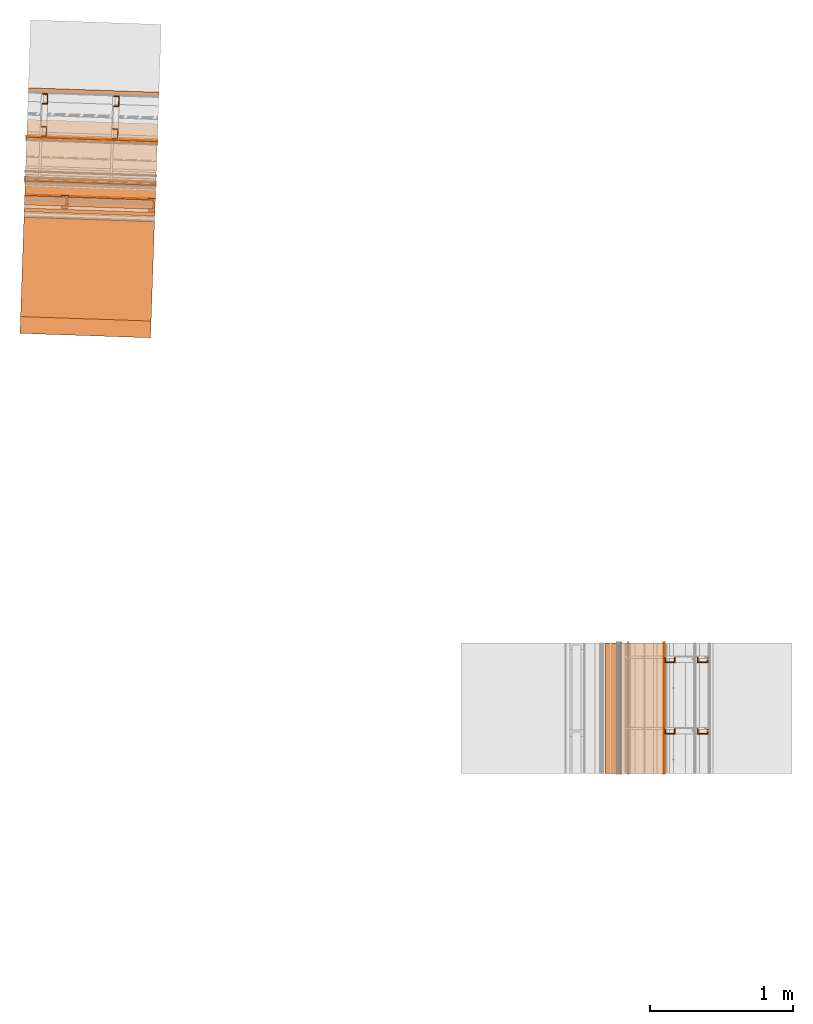
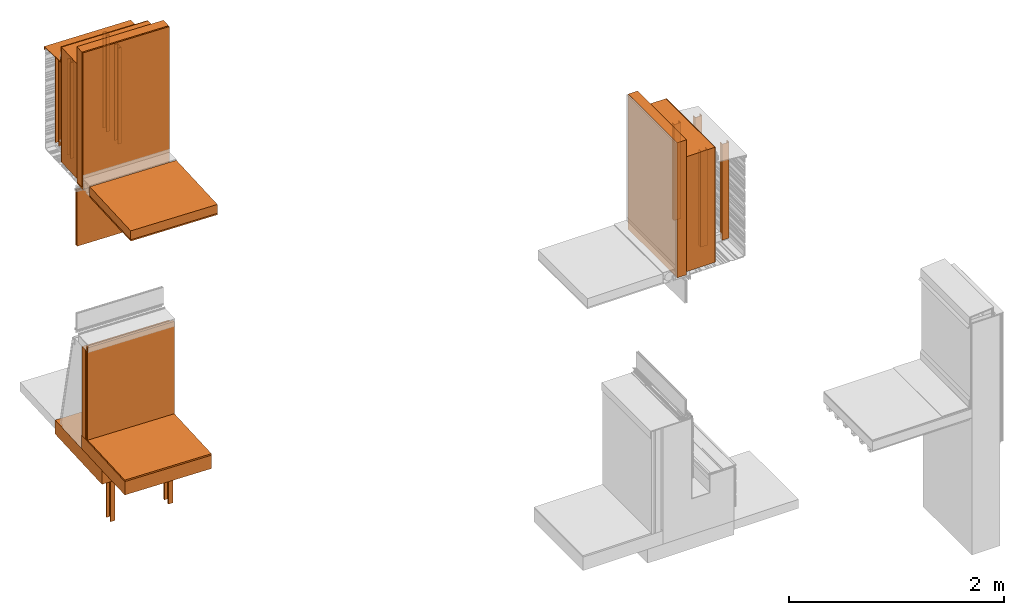
# One storey, part 2 of 36: 27 proxies.
"""IFC2X3 building model written with IfcOpenShell, lengths in feet."""

from ifc_helpers import new_model, entity, si_unit, converted_unit, derived_unit, direction, frame, frame_2d, origin, origin_2d_with_axis, place, context, subcontext, project, spatial, polyline, rectangle, outline, extrude, source, transform, mapped, material, type_object, type_shapes, element, save


model = new_model("IFC2X3")

# Units and contexts
model_context = context("Model", 3, precision=0.0001, world=origin(), true_north=direction((6.12303176911189e-17, 1.0)))
body_context = subcontext(model_context, "Body", "Model", "MODEL_VIEW")
ifc_project = project(units=[converted_unit("LENGTHUNIT", "FOOT", entity("IfcRatioMeasure", 0.3048), si_unit("LENGTHUNIT", "METRE"), dimensions=[1, 0, 0, 0, 0, 0, 0]), converted_unit("AREAUNIT", "SQUARE FOOT", entity("IfcRatioMeasure", 0.09290304), si_unit("AREAUNIT", "SQUARE_METRE"), dimensions=[2, 0, 0, 0, 0, 0, 0]), converted_unit("VOLUMEUNIT", "CUBIC FOOT", entity("IfcRatioMeasure", 0.028316846592), si_unit("VOLUMEUNIT", "CUBIC_METRE"), dimensions=[3, 0, 0, 0, 0, 0, 0]), converted_unit("PLANEANGLEUNIT", "DEGREE", entity("IfcRatioMeasure", 0.0174532925199433), si_unit("PLANEANGLEUNIT", "RADIAN"), dimensions=[0, 0, 0, 0, 0, 0, 0]), si_unit("MASSUNIT", "GRAM", prefix="KILO"), derived_unit("MASSDENSITYUNIT", [(si_unit("MASSUNIT", "GRAM", prefix="KILO"), 1), (si_unit("LENGTHUNIT", "METRE"), -3)]), si_unit("TIMEUNIT", "SECOND"), si_unit("FREQUENCYUNIT", "HERTZ"), si_unit("THERMODYNAMICTEMPERATUREUNIT", "DEGREE_CELSIUS"), derived_unit("THERMALTRANSMITTANCEUNIT", [(si_unit("MASSUNIT", "GRAM", prefix="KILO"), 1), (si_unit("THERMODYNAMICTEMPERATUREUNIT", "KELVIN"), -1), (si_unit("TIMEUNIT", "SECOND"), -3)]), derived_unit("VOLUMETRICFLOWRATEUNIT", [(si_unit("LENGTHUNIT", "METRE"), 3), (si_unit("TIMEUNIT", "SECOND"), -1)]), si_unit("ELECTRICCURRENTUNIT", "AMPERE"), si_unit("ELECTRICVOLTAGEUNIT", "VOLT"), si_unit("POWERUNIT", "WATT"), si_unit("FORCEUNIT", "NEWTON"), si_unit("ILLUMINANCEUNIT", "LUX"), si_unit("LUMINOUSFLUXUNIT", "LUMEN"), si_unit("LUMINOUSINTENSITYUNIT", "CANDELA"), derived_unit("USERDEFINED", [(si_unit("MASSUNIT", "GRAM", prefix="KILO"), -1), (si_unit("LENGTHUNIT", "METRE"), -2), (si_unit("TIMEUNIT", "SECOND"), 3), (si_unit("LUMINOUSFLUXUNIT", "LUMEN"), 1)]), derived_unit("LINEARVELOCITYUNIT", [(si_unit("LENGTHUNIT", "METRE"), 1), (si_unit("TIMEUNIT", "SECOND"), -1)]), si_unit("PRESSUREUNIT", "PASCAL"), derived_unit("USERDEFINED", [(si_unit("LENGTHUNIT", "METRE"), -2), (si_unit("MASSUNIT", "GRAM", prefix="KILO"), 1), (si_unit("TIMEUNIT", "SECOND"), -2)])], contexts=[model_context])

# Site, building, storey
site_placement = place(None, origin())
site = spatial("IfcSite", under=ifc_project, at=site_placement, CompositionType="ELEMENT")
building_placement = place(site_placement, origin())
building = spatial("IfcBuilding", under=site, at=building_placement, CompositionType="ELEMENT")
storey_placement = place(building_placement, origin())
storey = spatial("IfcBuildingStorey", under=building, at=storey_placement, Name="Level 1", CompositionType="ELEMENT", Elevation=0.0)

# Proxies
ifc_material_1 = material(Name="_EXISTING CAST-IN-PLACE CONCRETE")
building_element_proxy_type_1 = type_object("IfcBuildingElementProxyType", Name="Concrete wall001", PredefinedType="NOTDEFINED", material=ifc_material_1)
shared_shape_1 = source(origin(), body_context, "Body", "SweptSolid", [
    extrude(rectangle(XDim=3.00000000000001, YDim=1.00000000008858, at=origin_2d_with_axis()), frame((111.23211239903, -50.1693051540586, 9.875), z_axis=(0.0, 0.0, 1.0), x_axis=(-0.999414947916632, 0.0342017818365694, 0.0)), (0.0, 0.0, 1.0), 4.29166666666666),
])
type_shapes(building_element_proxy_type_1, [shared_shape_1])
proxy_1_placement = place(storey_placement, origin())
element("IfcBuildingElementProxy", 1, at=proxy_1_placement, inside=storey, type_object=building_element_proxy_type_1, material=ifc_material_1, Name="Concrete wall001:Concrete wall001", ObjectType="Concrete wall001", context=body_context, shape_type="MappedRepresentation", body=[
    mapped(shared_shape_1, transform((0.0, 0.0, 0.0), scale=1.0)),
])
ifc_material_2 = material(Name="METAL STUDS")
building_element_proxy_type_2 = type_object("IfcBuildingElementProxyType", Name="Metal stud 015", PredefinedType="NOTDEFINED", material=ifc_material_2)
shared_shape_2 = source(origin(), body_context, "Body", "SweptSolid", [
    extrude(outline(polyline([(-0.0661909448818871, -0.124999999999995), (0.0588090551181006, -0.124999999999995), (0.0588090551181176, -0.100393700787393), (-0.0514271653543104, -0.100393700787391), (-0.0514271653543313, 0.100393700787415), (0.0588090551181108, 0.100393700787414), (0.058809055118128, 0.12500000000001), (-0.0661909448818599, 0.125000000000017), (-0.0661909448818871, -0.124999999999995)])), frame((111.806856872744, -48.7923234996658, 9.875), z_axis=(0.0, 0.0, 1.0), x_axis=(-0.999414947916633, 0.0342017818365468, 0.0)), (0.0, 0.0, 1.0), 3.58333333333333),
])
type_shapes(building_element_proxy_type_2, [shared_shape_2])
proxy_2_placement = place(storey_placement, origin())
element("IfcBuildingElementProxy", 2, at=proxy_2_placement, inside=storey, type_object=building_element_proxy_type_2, material=ifc_material_2, Name="Metal stud 015:Metal stud 015", ObjectType="Metal stud 015", context=body_context, shape_type="MappedRepresentation", body=[
    mapped(shared_shape_2, transform((0.0, 0.0, 0.0), scale=1.0)),
])
ifc_material_3 = material(Name="Rigid insulation")
building_element_proxy_type_3 = type_object("IfcBuildingElementProxyType", Name="Insulation horizontal001", PredefinedType="NOTDEFINED", material=ifc_material_3)
shared_shape_3 = source(origin(), body_context, "Body", "SweptSolid", [
    extrude(rectangle(XDim=3.00000000000001, YDim=2.66666666666665, at=origin_2d_with_axis()), frame((111.140738303973, -52.8393600912109, 9.76041666666666), z_axis=(0.0, 0.0, 1.0), x_axis=(-0.999414947916632, 0.0342017818365552, 0.0)), (0.0, 0.0, 1.0), 0.333333333333334),
])
type_shapes(building_element_proxy_type_3, [shared_shape_3])
proxy_3_placement = place(storey_placement, origin())
element("IfcBuildingElementProxy", 3, at=proxy_3_placement, inside=storey, type_object=building_element_proxy_type_3, material=ifc_material_3, Name="Insulation horizontal001:Insulation horizontal001", ObjectType="Insulation horizontal001", context=body_context, shape_type="MappedRepresentation", body=[
    mapped(shared_shape_3, transform((0.0, 0.0, 0.0), scale=1.0)),
])
building_element_proxy_type_4 = type_object("IfcBuildingElementProxyType", Name="Insulation vertical001", PredefinedType="NOTDEFINED", material=ifc_material_3)
shared_shape_4 = source(origin(), body_context, "Body", "SweptSolid", [
    extrude(rectangle(XDim=3.0, YDim=0.333333333431768, at=frame_2d((-7.105427357601e-15, -2.4980018054066e-16), x_axis=(1.0, 0.0))), frame((111.209311383668, -50.835576744494, 9.76041698706119), z_axis=(0.0, 0.0, 1.0), x_axis=(-0.999414947916633, 0.0342017818365339, 0.0)), (0.0, 0.0, 1.0), 5.04166666666667),
])
type_shapes(building_element_proxy_type_4, [shared_shape_4])
proxy_4_placement = place(storey_placement, origin())
element("IfcBuildingElementProxy", 4, at=proxy_4_placement, inside=storey, type_object=building_element_proxy_type_4, material=ifc_material_3, Name="Insulation vertical001:Insulation vertical001", ObjectType="Insulation vertical001", context=body_context, shape_type="MappedRepresentation", body=[
    mapped(shared_shape_4, transform((0.0, 0.0, 0.0), scale=1.0)),
])
building_element_proxy_type_5 = type_object("IfcBuildingElementProxyType", Name="Inner gypsum board001", PredefinedType="NOTDEFINED", material=ifc_material_1)
shared_shape_5 = source(origin(), body_context, "Body", "SweptSolid", [
    extrude(outline(polyline([(-1.66319433764217, 0.0937483186701561), (3.37847232901137, 0.0937483186701561), (3.37847232901137, 0.145831652003495), (-1.7152779913692, 0.145831651839449), (-1.7152779913692, -0.239579970591649), (-1.66319433764217, -0.239579970591649), (-1.66319433764217, 0.0937483186701561)])), frame((109.707695024361, -50.8571497587533, 11.4236113247157), z_axis=(0.999414947916628, -0.0342017818366874, 0.0), x_axis=(0.0, 0.0, 1.0)), (0.0, 0.0, 1.0), 3.0),
])
type_shapes(building_element_proxy_type_5, [shared_shape_5])
proxy_5_placement = place(storey_placement, origin())
element("IfcBuildingElementProxy", 5, at=proxy_5_placement, inside=storey, type_object=building_element_proxy_type_5, material=ifc_material_1, Name="Inner gypsum board001:Inner gypsum board001", ObjectType="Inner gypsum board001", context=body_context, shape_type="MappedRepresentation", body=[
    mapped(shared_shape_5, transform((0.0, 0.0, 0.0), scale=1.0)),
])
building_element_proxy_type_6 = type_object("IfcBuildingElementProxyType", Name="Inner ceiling001", PredefinedType="NOTDEFINED", material=ifc_material_1)
shared_shape_6 = source(origin(), body_context, "Body", "SweptSolid", [
    extrude(rectangle(XDim=3.00000000000001, YDim=2.66666666666665, at=origin_2d_with_axis()), frame((111.140738303973, -52.8393600912109, 9.70833333333333), z_axis=(0.0, 0.0, 1.0), x_axis=(-0.999414947916632, 0.0342017818365552, 0.0)), (0.0, 0.0, 1.0), 0.0520833333333339),
])
type_shapes(building_element_proxy_type_6, [shared_shape_6])
proxy_6_placement = place(storey_placement, origin())
element("IfcBuildingElementProxy", 6, at=proxy_6_placement, inside=storey, type_object=building_element_proxy_type_6, material=ifc_material_1, Name="Inner ceiling001:Inner ceiling001", ObjectType="Inner ceiling001", context=body_context, shape_type="MappedRepresentation", body=[
    mapped(shared_shape_6, transform((0.0, 0.0, 0.0), scale=1.0)),
])
building_element_proxy_type_7 = type_object("IfcBuildingElementProxyType", Name="Metal stud 016", PredefinedType="NOTDEFINED", material=ifc_material_2)
shared_shape_7 = source(origin(), body_context, "Body", "SweptSolid", [
    extrude(outline(polyline([(-0.0661909448819011, -0.125000000000003), (0.0588090551180867, -0.125000000000003), (0.0588090551181036, -0.1003937007874), (-0.0514271653543243, -0.100393700787399), (-0.0514271653543453, 0.100393700787407), (0.0588090551180971, 0.100393700787399), (0.0588090551181141, 0.125000000000002), (-0.0661909448818737, 0.125000000000002), (-0.0661909448819011, -0.125000000000003)])), frame((110.167396656345, -48.7362182145008, 9.875), z_axis=(0.0, 0.0, 1.0), x_axis=(-0.999414947916633, 0.0342017818365468, 0.0)), (0.0, 0.0, 1.0), 3.58333333333333),
])
type_shapes(building_element_proxy_type_7, [shared_shape_7])
proxy_7_placement = place(storey_placement, origin())
element("IfcBuildingElementProxy", 7, at=proxy_7_placement, inside=storey, type_object=building_element_proxy_type_7, material=ifc_material_2, Name="Metal stud 016:Metal stud 016", ObjectType="Metal stud 016", context=body_context, shape_type="MappedRepresentation", body=[
    mapped(shared_shape_7, transform((0.0, 0.0, 0.0), scale=1.0)),
])
building_element_proxy_type_8 = type_object("IfcBuildingElementProxyType", Name="Metal stud 010", PredefinedType="NOTDEFINED", material=ifc_material_2)
shared_shape_8 = source(origin(), body_context, "Body", "SweptSolid", [
    extrude(outline(polyline([(-0.0661909448818864, -0.125000000000003), (0.0588090551180871, -0.125000000000003), (0.0588090551181182, -0.100393700787399), (-0.0514271653543239, -0.100393700787399), (-0.0514271653543454, 0.1003937007874), (0.0588090551180967, 0.1003937007874), (0.0588090551181136, 0.125000000000002), (-0.0661909448818741, 0.125000000000002), (-0.0661909448818864, -0.125000000000003)])), frame((110.141745319968, -49.4857794254381, 9.875), z_axis=(0.0, 0.0, 1.0), x_axis=(-0.999414947916632, 0.0342017818365507, 0.0)), (0.0, 0.0, 1.0), 3.58333333333333),
])
type_shapes(building_element_proxy_type_8, [shared_shape_8])
proxy_8_placement = place(storey_placement, origin())
element("IfcBuildingElementProxy", 8, at=proxy_8_placement, inside=storey, type_object=building_element_proxy_type_8, material=ifc_material_2, Name="Metal stud 010:Metal stud 010", ObjectType="Metal stud 010", context=body_context, shape_type="MappedRepresentation", body=[
    mapped(shared_shape_8, transform((0.0, 0.0, 0.0), scale=1.0)),
])
building_element_proxy_type_9 = type_object("IfcBuildingElementProxyType", Name="Metal stud 009", PredefinedType="NOTDEFINED", material=ifc_material_2)
shared_shape_9 = source(origin(), body_context, "Body", "SweptSolid", [
    extrude(outline(polyline([(-0.0661909448818866, -0.125000000000009), (0.0588090551181011, -0.125000000000009), (0.0588090551181181, -0.100393700787407), (-0.0514271653543099, -0.100393700787406), (-0.0514271653543308, 0.1003937007874), (0.0588090551181113, 0.1003937007874), (0.0588090551181285, 0.124999999999995), (-0.0661909448818592, 0.124999999999995), (-0.0661909448818866, -0.125000000000009)])), frame((111.781205536366, -49.5418847106031, 9.875), z_axis=(0.0, 0.0, 1.0), x_axis=(-0.999414947916633, 0.0342017818365468, 0.0)), (0.0, 0.0, 1.0), 3.58333333333333),
])
type_shapes(building_element_proxy_type_9, [shared_shape_9])
proxy_9_placement = place(storey_placement, origin())
element("IfcBuildingElementProxy", 9, at=proxy_9_placement, inside=storey, type_object=building_element_proxy_type_9, material=ifc_material_2, Name="Metal stud 009:Metal stud 009", ObjectType="Metal stud 009", context=body_context, shape_type="MappedRepresentation", body=[
    mapped(shared_shape_9, transform((0.0, 0.0, 0.0), scale=1.0)),
])
ifc_material_4 = material(Name="IMPERMEABLE WRB MEMBRANE")
building_element_proxy_type_10 = type_object("IfcBuildingElementProxyType", Name="WRB Membrane 004", PredefinedType="NOTDEFINED", material=ifc_material_4)
shared_shape_10 = source(origin(), body_context, "Body", "SweptSolid", [
    extrude(rectangle(XDim=2.99999999999999, YDim=0.0208333332447315, at=frame_2d((7.105427357601e-15, 2.42861286636753e-16), x_axis=(1.0, 0.0))), frame((111.249569558506, -49.6591871078143, 9.875), z_axis=(0.0, 0.0, 1.0), x_axis=(-0.999414947916641, 0.034201781836309, 0.0)), (0.0, 0.0, 1.0), 4.29166666666666),
])
type_shapes(building_element_proxy_type_10, [shared_shape_10])
proxy_10_placement = place(storey_placement, origin())
element("IfcBuildingElementProxy", 10, at=proxy_10_placement, inside=storey, type_object=building_element_proxy_type_10, material=ifc_material_4, Name="Membrane 004:Membrane 004", ObjectType="WRB Membrane 004", context=body_context, shape_type="MappedRepresentation", body=[
    mapped(shared_shape_10, transform((0.0, 0.0, 0.0), scale=1.0)),
])
ifc_material_5 = material(Name="SHEET METAL COPING")
building_element_proxy_type_11 = type_object("IfcBuildingElementProxyType", Name="Counter-flashing 003", PredefinedType="NOTDEFINED", material=ifc_material_5)
shared_shape_11 = source(origin(), body_context, "Body", "SweptSolid", [
    extrude(outline(polyline([(-0.122649832506566, -0.374644447526208), (-0.0243207540124697, -0.374644447526208), (0.0785724214419599, 0.687403667831295), (0.260425070602032, 0.687403667831295), (0.260425070602032, 0.708596612431124), (0.0592285252280131, 0.708596612431124), (-0.0436645732176881, -0.353447146017061), (-0.101456535928893, -0.353447146017061), (-0.101456535928893, -0.344552994114148), (-0.0712265118864863, -0.344552994114148), (-0.0712265118864863, -0.32335569260498), (-0.122649832506566, -0.32335569260498), (-0.122649832506566, -0.374644447526208)])), frame((109.776156128618, -48.8566384616609, 13.5125295948507), z_axis=(0.999414947916627, -0.0342017818367098, 0.0), x_axis=(0.0, 0.0, 1.0)), (0.0, 0.0, 1.0), 3.00000000000001),
])
type_shapes(building_element_proxy_type_11, [shared_shape_11])
proxy_11_placement = place(storey_placement, origin())
element("IfcBuildingElementProxy", 11, at=proxy_11_placement, inside=storey, type_object=building_element_proxy_type_11, material=ifc_material_5, Name="Counter-flashing 003:Counter-flashing 003", ObjectType="Counter-flashing 003", context=body_context, shape_type="MappedRepresentation", body=[
    mapped(shared_shape_11, transform((0.0, 0.0, 0.0), scale=1.0)),
])
ifc_material_6 = material(Name="Clear glass")
building_element_proxy_type_12 = type_object("IfcBuildingElementProxyType", Name="Glass panel 004", PredefinedType="NOTDEFINED", material=ifc_material_6)
shared_shape_12 = source(origin(), body_context, "Body", "SweptSolid", [
    extrude(rectangle(XDim=3.0, YDim=0.0156250000000221, at=frame_2d((7.105427357601e-15, 2.42861286636753e-16), x_axis=(1.0, 0.0))), frame((111.2150071805, -50.6691390856105, 7.3556443373819), z_axis=(0.0, 0.0, 1.0), x_axis=(-0.999414947916601, 0.0342017818374624, 0.0)), (0.0, 0.0, 1.0), 2.094323495),
])
type_shapes(building_element_proxy_type_12, [shared_shape_12])
proxy_12_placement = place(storey_placement, origin())
element("IfcBuildingElementProxy", 12, at=proxy_12_placement, inside=storey, type_object=building_element_proxy_type_12, material=ifc_material_6, Name="Glass panel 004:Glass panel 004", ObjectType="Glass panel 004", context=body_context, shape_type="MappedRepresentation", body=[
    mapped(shared_shape_12, transform((0.0, 0.0, 0.0), scale=1.0)),
])
building_element_proxy_type_13 = type_object("IfcBuildingElementProxyType", Name="Glass panel 003", PredefinedType="NOTDEFINED", material=ifc_material_6)
shared_shape_13 = source(origin(), body_context, "Body", "SweptSolid", [
    extrude(rectangle(XDim=3.0, YDim=0.0156250000000221, at=frame_2d((-7.32747196252603e-15, 6.8590966240123e-15), x_axis=(1.0, 0.0))), frame((111.217317225848, -50.6016369343366, 7.3556443373819), z_axis=(0.0, 0.0, 1.0), x_axis=(-0.999414947916601, 0.0342017818374624, 0.0)), (0.0, 0.0, 1.0), 2.094323495),
])
type_shapes(building_element_proxy_type_13, [shared_shape_13])
proxy_13_placement = place(storey_placement, origin())
element("IfcBuildingElementProxy", 13, at=proxy_13_placement, inside=storey, type_object=building_element_proxy_type_13, material=ifc_material_6, Name="Glass panel 003:Glass panel 003", ObjectType="Glass panel 003", context=body_context, shape_type="MappedRepresentation", body=[
    mapped(shared_shape_13, transform((0.0, 0.0, 0.0), scale=1.0)),
])
building_element_proxy_type_14 = type_object("IfcBuildingElementProxyType", Name="Foundation block001", PredefinedType="NOTDEFINED", material=ifc_material_1)
shared_shape_14 = source(origin(), body_context, "Body", "SweptSolid", [
    extrude(rectangle(XDim=3.00000000000001, YDim=3.04223472971457, at=frame_2d((-7.105427357601e-15, -2.22044604925031e-16), x_axis=(1.0, 0.0))), frame((111.211221314862, -50.7797663837241, -0.520833333333323), z_axis=(0.0, 0.0, 1.0), x_axis=(0.999414947916632, -0.0342017818365576, 0.0)), (0.0, 0.0, 1.0), 0.520833333333323),
])
type_shapes(building_element_proxy_type_14, [shared_shape_14])
proxy_14_placement = place(storey_placement, origin())
element("IfcBuildingElementProxy", 14, at=proxy_14_placement, inside=storey, type_object=building_element_proxy_type_14, material=ifc_material_1, Name="Foundation block001:Foundation block001", ObjectType="Foundation block001", context=body_context, shape_type="MappedRepresentation", body=[
    mapped(shared_shape_14, transform((0.0, 0.0, 0.0), scale=1.0)),
])
building_element_proxy_type_15 = type_object("IfcBuildingElementProxyType", Name="Gypsum panel001", PredefinedType="NOTDEFINED", material=ifc_material_1)
shared_shape_15 = source(origin(), body_context, "Body", "SweptSolid", [
    extrude(rectangle(XDim=3.00000000000001, YDim=0.0820456841361503, at=frame_2d((-7.105427357601e-15, -2.42861286636753e-16), x_axis=(1.0, 0.0))), frame((111.192234935923, -51.3345699611985, 0.500000000000006), z_axis=(0.0, 0.0, 1.0), x_axis=(0.999414947916627, -0.0342017818367044, 0.0)), (0.0, 0.0, 1.0), 3.5),
])
type_shapes(building_element_proxy_type_15, [shared_shape_15])
proxy_15_placement = place(storey_placement, origin())
element("IfcBuildingElementProxy", 15, at=proxy_15_placement, inside=storey, type_object=building_element_proxy_type_15, material=ifc_material_1, Name="Gypsum panel001:Gypsum panel001", ObjectType="Gypsum panel001", context=body_context, shape_type="MappedRepresentation", body=[
    mapped(shared_shape_15, transform((0.0, 0.0, 0.0), scale=1.0)),
])
building_element_proxy_type_16 = type_object("IfcBuildingElementProxyType", Name="Floor structure001", PredefinedType="NOTDEFINED", material=ifc_material_1)
shared_shape_16 = source(origin(), body_context, "Body", "SweptSolid", [
    extrude(rectangle(XDim=3.0, YDim=2.81767872375655, at=frame_2d((7.105427357601e-15, 2.22044604925031e-16), x_axis=(1.0, 0.0))), frame((111.156508593296, -52.3785343086102, 0.0), z_axis=(0.0, 0.0, 1.0), x_axis=(0.999414947916632, -0.0342017818365529, 0.0)), (0.0, 0.0, 1.0), 0.500000000000006),
])
type_shapes(building_element_proxy_type_16, [shared_shape_16])
proxy_16_placement = place(storey_placement, origin())
element("IfcBuildingElementProxy", 16, at=proxy_16_placement, inside=storey, type_object=building_element_proxy_type_16, material=ifc_material_1, Name="Floor structure001:Floor structure001", ObjectType="Floor structure001", context=body_context, shape_type="MappedRepresentation", body=[
    mapped(shared_shape_16, transform((0.0, 0.0, 0.0), scale=1.0)),
])
building_element_proxy_type_17 = type_object("IfcBuildingElementProxyType", Name="Insulation001", PredefinedType="NOTDEFINED", material=ifc_material_3)
shared_shape_17 = source(origin(), body_context, "Body", "SweptSolid", [
    extrude(rectangle(XDim=3.0, YDim=0.208333333333335, at=frame_2d((6.77236045021345e-15, 7.34134975033385e-15), x_axis=(1.0, 0.0))), frame((111.199694555751, -51.1165913892693, 0.500000000000006), z_axis=(0.0, 0.0, 1.0), x_axis=(0.99941494791663, -0.0342017818366216, 0.0)), (0.0, 0.0, 1.0), 3.33333333333333),
])
type_shapes(building_element_proxy_type_17, [shared_shape_17])
proxy_17_placement = place(storey_placement, origin())
element("IfcBuildingElementProxy", 17, at=proxy_17_placement, inside=storey, type_object=building_element_proxy_type_17, material=ifc_material_3, Name="Insulation001:Insulation001", ObjectType="Insulation001", context=body_context, shape_type="MappedRepresentation", body=[
    mapped(shared_shape_17, transform((0.0, 0.0, 0.0), scale=1.0)),
])
building_element_proxy_type_18 = type_object("IfcBuildingElementProxyType", Name="Metal stud002", PredefinedType="NOTDEFINED", material=ifc_material_2)
shared_shape_18 = source(origin(), body_context, "Body", "SweptSolid", [
    extrude(outline(polyline([(-0.0876338087680618, -0.148437500000005), (0.0644366447096374, -0.148437500000005), (0.064436644709634, -0.106770833333343), (-0.0412394806512756, -0.106770833333348), (-0.0412394806512653, 0.101562500000001), (0.0644366447096304, 0.101562499999999), (0.0644366447096367, 0.153645833333331), (-0.0876338087680624, 0.153645833333331), (-0.0876338087680618, -0.148437500000005)])), frame((112.611145372063, -51.1674994726279, -2.83333333333366), z_axis=(0.0, 0.0, 1.0), x_axis=(-0.999414947916632, 0.0342017818365708, 0.0)), (0.0, 0.0, 1.0), 3.33333333333333),
])
type_shapes(building_element_proxy_type_18, [shared_shape_18])
proxy_18_placement = place(storey_placement, origin())
element("IfcBuildingElementProxy", 18, at=proxy_18_placement, inside=storey, type_object=building_element_proxy_type_18, material=ifc_material_2, Name="Metal stud002:Metal stud002", ObjectType="Metal stud002", context=body_context, shape_type="MappedRepresentation", body=[
    mapped(shared_shape_18, transform((0.0, 0.0, 0.0), scale=1.0)),
])
ifc_material_7 = material(Name="Metallic support for window frame")
building_element_proxy_type_19 = type_object("IfcBuildingElementProxyType", Name="Floor covering material001", PredefinedType="NOTDEFINED", material=ifc_material_7)
shared_shape_19 = source(origin(), body_context, "Body", "SweptSolid", [
    extrude(rectangle(XDim=3.00000000000001, YDim=2.41239199827756, at=origin_2d_with_axis()), frame((111.149577829216, -52.5810591143429, 0.500000000000006), z_axis=(0.0, 0.0, 1.0), x_axis=(0.999414947916632, -0.0342017818365623, 0.0)), (0.0, 0.0, 1.0), 0.0564560977821522),
])
type_shapes(building_element_proxy_type_19, [shared_shape_19])
proxy_19_placement = place(storey_placement, origin())
element("IfcBuildingElementProxy", 19, at=proxy_19_placement, inside=storey, type_object=building_element_proxy_type_19, material=ifc_material_7, Name="Floor covering material001:Floor covering material001", ObjectType="Floor covering material001", context=body_context, shape_type="MappedRepresentation", body=[
    mapped(shared_shape_19, transform((0.0, 0.0, 0.0), scale=1.0)),
])
building_element_proxy_type_20 = type_object("IfcBuildingElementProxyType", Name="Metal stud003", PredefinedType="NOTDEFINED", material=ifc_material_2)
shared_shape_20 = source(origin(), body_context, "Body", "SweptSolid", [
    extrude(outline(polyline([(-0.0876338087680401, -0.148437500000007), (0.0644366447096588, -0.148437500000007), (0.0644366447096577, -0.106770833333352), (-0.0412394806512522, -0.106770833333345), (-0.0412394806512319, 0.101562499999996), (0.0644366447096636, 0.101562499999997), (0.0644366447096723, 0.153645833333329), (-0.0876338087680266, 0.153645833333329), (-0.0876338087680401, -0.148437500000007)])), frame((110.612315476229, -51.0990959089548, -2.83333333333366), z_axis=(0.0, 0.0, 1.0), x_axis=(-0.999414947916633, 0.0342017818365241, 0.0)), (0.0, 0.0, 1.0), 3.33333333333333),
])
type_shapes(building_element_proxy_type_20, [shared_shape_20])
proxy_20_placement = place(storey_placement, origin())
element("IfcBuildingElementProxy", 20, at=proxy_20_placement, inside=storey, type_object=building_element_proxy_type_20, material=ifc_material_2, Name="Metal stud003:Metal stud003", ObjectType="Metal stud003", context=body_context, shape_type="MappedRepresentation", body=[
    mapped(shared_shape_20, transform((0.0, 0.0, 0.0), scale=1.0)),
])
building_element_proxy_type_21 = type_object("IfcBuildingElementProxyType", Name="Concrete wall005", PredefinedType="NOTDEFINED", material=ifc_material_1)
shared_shape_21 = source(origin(), body_context, "Body", "SweptSolid", [
    extrude(rectangle(XDim=3.0, YDim=1.00000000008858, at=frame_2d((0.0, 7.105427357601e-15), x_axis=(1.0, 0.0))), frame((123.87686837011, -62.7284331589239, 9.875), z_axis=(0.0, 0.0, 1.0), x_axis=(0.0, 1.0, 0.0)), (0.0, 0.0, 1.0), 4.29166666666667),
])
type_shapes(building_element_proxy_type_21, [shared_shape_21])
proxy_21_placement = place(storey_placement, origin())
element("IfcBuildingElementProxy", 21, at=proxy_21_placement, inside=storey, type_object=building_element_proxy_type_21, material=ifc_material_1, Name="Concrete wall005:Concrete wall005", ObjectType="Concrete wall005", context=body_context, shape_type="MappedRepresentation", body=[
    mapped(shared_shape_21, transform((0.0, 0.0, 0.0), scale=1.0)),
])
building_element_proxy_type_22 = type_object("IfcBuildingElementProxyType", Name="Insulation vertical003", PredefinedType="NOTDEFINED", material=ifc_material_1)
shared_shape_22 = source(origin(), body_context, "Body", "SweptSolid", [
    extrude(rectangle(XDim=3.0, YDim=0.333333333431767, at=origin_2d_with_axis()), frame((123.210206747904, -62.7284331589239, 9.76041698706119), z_axis=(0.0, 0.0, 1.0), x_axis=(0.0, 1.0, 0.0)), (0.0, 0.0, 1.0), 5.04166666666667),
])
type_shapes(building_element_proxy_type_22, [shared_shape_22])
proxy_22_placement = place(storey_placement, origin())
element("IfcBuildingElementProxy", 22, at=proxy_22_placement, inside=storey, type_object=building_element_proxy_type_22, material=ifc_material_1, Name="Insulation vertical003:Insulation vertical003", ObjectType="Insulation vertical003", context=body_context, shape_type="MappedRepresentation", body=[
    mapped(shared_shape_22, transform((0.0, 0.0, 0.0), scale=1.0)),
])
building_element_proxy_type_23 = type_object("IfcBuildingElementProxyType", Name="WRB Membrane 010", PredefinedType="NOTDEFINED", material=ifc_material_1)
shared_shape_23 = source(origin(), body_context, "Body", "SweptSolid", [
    extrude(rectangle(XDim=3.0, YDim=0.0208333332447381, at=frame_2d((0.0, -7.105427357601e-15), x_axis=(1.0, 0.0))), frame((124.387285036688, -62.7284331589239, 9.875), z_axis=(0.0, 0.0, 1.0), x_axis=(0.0, 1.0, 0.0)), (0.0, 0.0, 1.0), 4.29166666666667),
])
type_shapes(building_element_proxy_type_23, [shared_shape_23])
proxy_23_placement = place(storey_placement, origin())
element("IfcBuildingElementProxy", 23, at=proxy_23_placement, inside=storey, type_object=building_element_proxy_type_23, material=ifc_material_1, Name="Membrane 010:Membrane 010", ObjectType="WRB Membrane 010", context=body_context, shape_type="MappedRepresentation", body=[
    mapped(shared_shape_23, transform((0.0, 0.0, 0.0), scale=1.0)),
])
building_element_proxy_type_24 = type_object("IfcBuildingElementProxyType", Name="Metal stud 025", PredefinedType="NOTDEFINED", material=ifc_material_1)
shared_shape_24 = source(origin(), body_context, "Body", "SweptSolid", [
    extrude(outline(polyline([(-0.066190944881896, -0.125000000000014), (0.058809055118104, -0.125000000000014), (0.058809055118104, -0.100393700787407), (-0.0514271653543332, -0.100393700787407), (-0.0514271653543332, 0.100393700787393), (0.058809055118104, 0.100393700787393), (0.058809055118104, 0.124999999999986), (-0.066190944881896, 0.124999999999986), (-0.066190944881896, -0.125000000000014)])), frame((125.272701703619, -63.2557461510499, 9.875), z_axis=(0.0, 0.0, 1.0), x_axis=(0.0, 1.0, 0.0)), (0.0, 0.0, 1.0), 3.58333333333333),
])
type_shapes(building_element_proxy_type_24, [shared_shape_24])
proxy_24_placement = place(storey_placement, origin())
element("IfcBuildingElementProxy", 24, at=proxy_24_placement, inside=storey, type_object=building_element_proxy_type_24, material=ifc_material_1, Name="Metal stud 025:Metal stud 025", ObjectType="Metal stud 025", context=body_context, shape_type="MappedRepresentation", body=[
    mapped(shared_shape_24, transform((0.0, 0.0, 0.0), scale=1.0)),
])
building_element_proxy_type_25 = type_object("IfcBuildingElementProxyType", Name="Metal stud 029", PredefinedType="NOTDEFINED", material=ifc_material_1)
shared_shape_25 = source(origin(), body_context, "Body", "SweptSolid", [
    extrude(outline(polyline([(-0.0661909448818889, -0.125000000000014), (0.0588090551181111, -0.125000000000014), (0.0588090551181111, -0.100393700787407), (-0.0514271653543332, -0.100393700787407), (-0.0514271653543332, 0.100393700787393), (0.0588090551181111, 0.100393700787393), (0.0588090551181111, 0.124999999999986), (-0.0661909448818889, 0.124999999999986), (-0.0661909448818889, -0.125000000000014)])), frame((125.272701703619, -61.6153262035433, 9.875), z_axis=(0.0, 0.0, 1.0), x_axis=(0.0, 1.0, 0.0)), (0.0, 0.0, 1.0), 3.58333333333333),
])
type_shapes(building_element_proxy_type_25, [shared_shape_25])
proxy_25_placement = place(storey_placement, origin())
element("IfcBuildingElementProxy", 25, at=proxy_25_placement, inside=storey, type_object=building_element_proxy_type_25, material=ifc_material_1, Name="Metal stud 029:Metal stud 029", ObjectType="Metal stud 029", context=body_context, shape_type="MappedRepresentation", body=[
    mapped(shared_shape_25, transform((0.0, 0.0, 0.0), scale=1.0)),
])
building_element_proxy_type_26 = type_object("IfcBuildingElementProxyType", Name="Metal stud 030", PredefinedType="NOTDEFINED", material=ifc_material_1)
shared_shape_26 = source(origin(), body_context, "Body", "SweptSolid", [
    extrude(outline(polyline([(-0.0661909448818889, -0.125000000000014), (0.0588090551181111, -0.125000000000014), (0.0588090551181111, -0.100393700787407), (-0.0514271653543332, -0.100393700787407), (-0.0514271653543332, 0.100393700787393), (0.0588090551181111, 0.100393700787393), (0.0588090551181111, 0.124999999999986), (-0.0661909448818889, 0.124999999999986), (-0.0661909448818889, -0.125000000000014)])), frame((124.522701703619, -61.6153262035433, 9.875), z_axis=(0.0, 0.0, 1.0), x_axis=(0.0, 1.0, 0.0)), (0.0, 0.0, 1.0), 3.58333333333333),
])
type_shapes(building_element_proxy_type_26, [shared_shape_26])
proxy_26_placement = place(storey_placement, origin())
element("IfcBuildingElementProxy", 26, at=proxy_26_placement, inside=storey, type_object=building_element_proxy_type_26, material=ifc_material_1, Name="Metal stud 030:Metal stud 030", ObjectType="Metal stud 030", context=body_context, shape_type="MappedRepresentation", body=[
    mapped(shared_shape_26, transform((0.0, 0.0, 0.0), scale=1.0)),
])
building_element_proxy_type_27 = type_object("IfcBuildingElementProxyType", Name="Metal stud 031", PredefinedType="NOTDEFINED", material=ifc_material_1)
shared_shape_27 = source(origin(), body_context, "Body", "SweptSolid", [
    extrude(outline(polyline([(-0.066190944881896, -0.125000000000014), (0.058809055118104, -0.125000000000014), (0.058809055118104, -0.100393700787407), (-0.0514271653543332, -0.100393700787407), (-0.0514271653543332, 0.100393700787393), (0.058809055118104, 0.100393700787393), (0.058809055118104, 0.124999999999986), (-0.066190944881896, 0.124999999999986), (-0.066190944881896, -0.125000000000014)])), frame((124.522701703619, -63.2557461510499, 9.875), z_axis=(0.0, 0.0, 1.0), x_axis=(0.0, 1.0, 0.0)), (0.0, 0.0, 1.0), 3.58333333333333),
])
type_shapes(building_element_proxy_type_27, [shared_shape_27])
proxy_27_placement = place(storey_placement, origin())
element("IfcBuildingElementProxy", 27, at=proxy_27_placement, inside=storey, type_object=building_element_proxy_type_27, material=ifc_material_1, Name="Metal stud 031:Metal stud 031", ObjectType="Metal stud 031", context=body_context, shape_type="MappedRepresentation", body=[
    mapped(shared_shape_27, transform((0.0, 0.0, 0.0), scale=1.0)),
])

save(model, "model.ifc")
